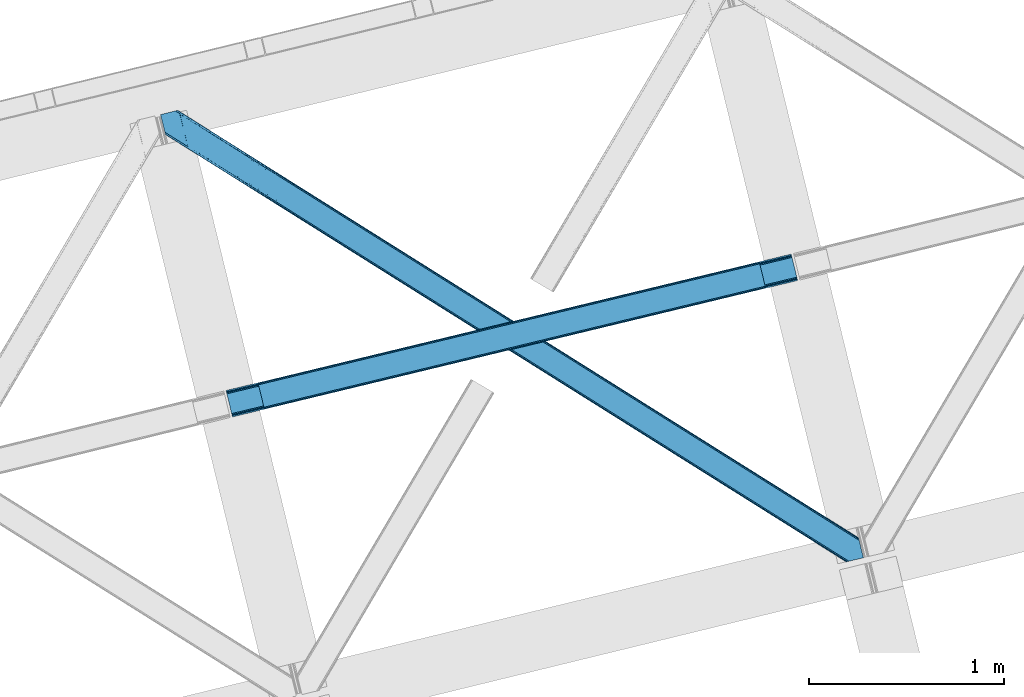
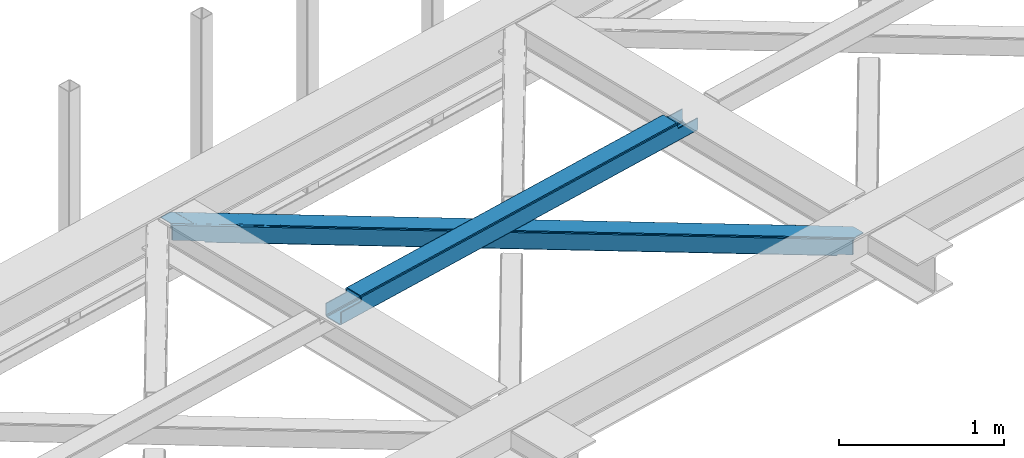
# One storey, part 20 of 67: 1 beam, 1 member.
"""IFC4 building model written with IfcOpenShell, lengths in millimetres."""

from ifc_helpers import new_model, entity, si_unit, converted_unit, derived_unit, direction, frame, origin, place, context, subcontext, project, spatial, triangles, polygons, material, type_object, element, save


model = new_model("IFC4")

# Units and contexts
model_context = context("Model", 3, precision=0.01, world=origin(), true_north=direction((6.12303176911189e-17, 1.0)))
plan_context = context("Plan", 3, precision=0.01, world=origin(), true_north=direction((6.12303176911189e-17, 1.0)))
body_context = subcontext(model_context, "Body", "Model", "MODEL_VIEW")
ifc_project = project(units=[si_unit("LENGTHUNIT", "METRE", prefix="MILLI"), si_unit("AREAUNIT", "SQUARE_METRE"), si_unit("VOLUMEUNIT", "CUBIC_METRE"), converted_unit("PLANEANGLEUNIT", "DEGREE", entity("IfcRatioMeasure", 0.0174532925199433), si_unit("PLANEANGLEUNIT", "RADIAN"), dimensions=[0, 0, 0, 0, 0, 0, 0]), si_unit("MASSUNIT", "GRAM", prefix="KILO"), derived_unit("MASSDENSITYUNIT", [(si_unit("MASSUNIT", "GRAM", prefix="KILO"), 1), (si_unit("LENGTHUNIT", "METRE"), -3)]), derived_unit("MOMENTOFINERTIAUNIT", [(si_unit("LENGTHUNIT", "METRE"), 4)]), si_unit("TIMEUNIT", "SECOND"), si_unit("FREQUENCYUNIT", "HERTZ"), si_unit("THERMODYNAMICTEMPERATUREUNIT", "DEGREE_CELSIUS"), derived_unit("THERMALTRANSMITTANCEUNIT", [(si_unit("MASSUNIT", "GRAM", prefix="KILO"), 1), (si_unit("THERMODYNAMICTEMPERATUREUNIT", "KELVIN"), -1), (si_unit("TIMEUNIT", "SECOND"), -3)]), derived_unit("VOLUMETRICFLOWRATEUNIT", [(si_unit("LENGTHUNIT", "METRE"), 3), (si_unit("TIMEUNIT", "SECOND"), -1)]), derived_unit("MASSFLOWRATEUNIT", [(si_unit("MASSUNIT", "GRAM", prefix="KILO"), 1), (si_unit("TIMEUNIT", "SECOND"), -1)]), derived_unit("ROTATIONALFREQUENCYUNIT", [(si_unit("TIMEUNIT", "SECOND"), -1)]), si_unit("ELECTRICCURRENTUNIT", "AMPERE"), si_unit("ELECTRICVOLTAGEUNIT", "VOLT"), si_unit("POWERUNIT", "WATT"), si_unit("FORCEUNIT", "NEWTON", prefix="KILO"), si_unit("ILLUMINANCEUNIT", "LUX"), si_unit("LUMINOUSFLUXUNIT", "LUMEN"), si_unit("LUMINOUSINTENSITYUNIT", "CANDELA"), derived_unit("USERDEFINED", [(si_unit("MASSUNIT", "GRAM", prefix="KILO"), -1), (si_unit("LENGTHUNIT", "METRE"), -2), (si_unit("TIMEUNIT", "SECOND"), 3), (si_unit("LUMINOUSFLUXUNIT", "LUMEN"), 1)]), derived_unit("LINEARVELOCITYUNIT", [(si_unit("LENGTHUNIT", "METRE"), 1), (si_unit("TIMEUNIT", "SECOND"), -1)]), si_unit("PRESSUREUNIT", "PASCAL"), derived_unit("USERDEFINED", [(si_unit("LENGTHUNIT", "METRE"), -2), (si_unit("MASSUNIT", "GRAM", prefix="KILO"), 1), (si_unit("TIMEUNIT", "SECOND"), -2)]), derived_unit("LINEARFORCEUNIT", [(si_unit("MASSUNIT", "GRAM", prefix="KILO"), 1), (si_unit("LENGTHUNIT", "METRE"), 1), (si_unit("TIMEUNIT", "SECOND"), -2), (si_unit("LENGTHUNIT", "METRE"), -1)]), derived_unit("PLANARFORCEUNIT", [(si_unit("MASSUNIT", "GRAM", prefix="KILO"), 1), (si_unit("LENGTHUNIT", "METRE"), 1), (si_unit("TIMEUNIT", "SECOND"), -2), (si_unit("LENGTHUNIT", "METRE"), -2)])], contexts=[model_context, plan_context])

# Site, building, storey
site_placement = place(None, origin())
site = spatial("IfcSite", under=ifc_project, at=site_placement, CompositionType="ELEMENT")
building_placement = place(site_placement, origin())
building = spatial("IfcBuilding", under=site, at=building_placement, CompositionType="ELEMENT")
storey_placement = place(building_placement, frame((0.0, 0.0, 19800.0)))
storey = spatial("IfcBuildingStorey", under=building, at=storey_placement, CompositionType="ELEMENT", Elevation=19800.0)

# Beam
ifc_material = material(Name="Metal painted (White)")
beam_type = type_object("IfcBeamType", PredefinedType="BEAM")
beam_placement = place(storey_placement, frame((-57740.4120145872, 5065.0921010713, 3967.02213739874)))
element("IfcBeam", 1, at=beam_placement, inside=storey, type_object=beam_type, material=ifc_material, ObjectType="Steel Beam", PredefinedType="BEAM", context=body_context, shape_type="Tessellation", body=[
    polygons([(195.780301044213, 46.4550586676728, 115.555285086674), (195.464822269693, 47.7492743886278, 122.252244531344), (2771.48985192152, 669.545541676776, 123.117713426555), (2771.80533069603, 668.25132595583, 116.42075398189), (194.566414729762, 51.4348889400316, 127.929650650905), (2770.59144438158, 673.231156228175, 128.795119546121), (193.221852828265, 56.9508009166206, 131.72316982947), (2769.24688248008, 678.747068204764, 132.588638724685), (191.635833926232, 63.4572627218112, 133.055273160435), (2767.66086357805, 685.253530009973, 133.920742055651), (170.084604912774, 151.868723803345, 133.055206290887), (2746.10963456458, 773.664991091508, 133.920675186102), (168.498586010742, 158.37518560857, 131.723093117664), (2744.52361566255, 780.171452896718, 132.588562012879), (167.154024109253, 163.891097585162, 127.929565595236), (2743.17905376107, 785.687364873307, 128.795034490451), (166.255616569314, 167.576712136562, 122.252153900486), (2742.28064622113, 789.372979424712, 123.117622795697), (165.940137794803, 168.870927857489, 115.55519249807), (2741.96516744662, 790.667195145647, 116.420661393281), (2740.30738059942, 797.468076767305, 101.477862601255), (2740.30738059942, 797.468076767303, 123.420656622786), (2740.62285937394, 796.173861046351, 130.117618025197), (2741.52126691387, 792.488246494948, 135.795029719952), (2742.86582881537, 786.97233451836, 139.58855724238), (2744.4518477174, 780.465872713163, 140.920670415603), (2769.31865042523, 678.452648388318, 140.920747572779), (2770.90466932728, 671.946186583087, 139.588644241809), (2772.24923122876, 666.430274606496, 135.795125063245), (2773.1476387687, 662.744660055096, 130.117718943684), (2773.46311754411, 661.450444330471, 123.420759499014), (2773.46311754321, 661.450444334177, 101.477862601255), (2771.80533069603, 668.251325955834, 101.477862601255), (2741.96516744661, 790.667195145648, 101.477862601255), (165.940137794803, 168.870927857486, 100.498086492688), (195.780301044213, 46.4550586676718, 100.498086492688), (197.438087891481, 39.6541770456987, 100.498086492688), (197.438087891403, 39.654177046016, 122.555290603803), (197.122609116892, 40.9483927669546, 129.252250048473), (196.224201576953, 44.6340073183542, 134.929656168034), (194.879639675456, 50.1499192949453, 138.723175346598), (193.293620773432, 56.6563811001544, 140.055278677564), (168.426818065593, 158.669605425, 140.055201520392), (166.840799163551, 165.17606723021, 138.723088347169), (165.496237262063, 170.6919792068, 134.929560824741), (164.597829722123, 174.377593758201, 129.252149129991), (164.282350947612, 175.671809479143, 122.555187727571), (164.282350947612, 175.671809479143, 100.498086492688), (2936.08768164363, 707.905503001759, 100.477862601264), (2936.08768164363, 707.90550300176, 25.4759431828493), (31.4979500966092, 6.80088162175, 24.5000861794941), (31.4979500966092, 6.80088162174783, 99.4980864926921), (194.80821612737, 46.2204185668087, 99.4980864926878), (1.65778684719908, 129.216750811564, 24.4999935908851), (2906.24751839422, 830.321372191575, 25.4758505942445), (2906.24751839422, 830.321372191573, 100.47786260126), (2742.93725236347, 790.901835246512, 100.47786260126), (1.65778684719908, 129.216750811561, 99.4980864926921), (2937.74546849234, 701.104621373772, 18.4759479533483), (2937.74546849731, 701.104621353716, 100.477862601264), (2774.43520246224, 661.685084426048, 100.47786260126), (33.1557369438083, 4.43975523012341e-11, 99.4980864926921), (33.1557369430373, 3.22152970966272e-09, 17.5000909499889), (2904.58973154703, 837.122253813229, 100.47786260126), (2904.58973154703, 837.122253813231, 18.4758450771161), (0.0, 136.01763243322, 17.4999880737609), (8.66293703438714e-12, 136.017632433219, 99.4980864926921), (163.310266030769, 175.437169378279, 99.4980864926878), (2772.77741561287, 668.485966056697, 100.47786260126), (2741.27946551628, 797.702716868168, 100.47786260126), (2906.56299716874, 829.027156470638, 18.7788911495745), (2907.46140470868, 825.341541919235, 13.1014850300135), (2908.80596661015, 819.825629942646, 9.30796585144909), (2910.39198551221, 813.319168137436, 7.9758625204836), (2931.94321452565, 724.907707055902, 7.97592939003242), (2933.52923342769, 718.401245250692, 9.30804256325522), (2934.87379532918, 712.885333274101, 13.1015700856834), (2935.77220286912, 709.199718722701, 18.7789817804291), (2937.4299897163, 702.398837101065, 11.7789865509282), (2936.53158217636, 706.084451652467, 6.10157485617812), (2935.18702027487, 711.600363629058, 2.30804733374998), (2933.60100137285, 718.106825434246, 0.975934160527186), (2908.73419866501, 820.120049759092, 0.975857003355134), (2907.14817976297, 826.626511564317, 2.30796033432063), (2905.80361786149, 832.142423540906, 6.10147951288502), (2904.90521032155, 835.828038092307, 11.778885632446), (196.466002974552, 39.4195369451518, 99.4980864926921), (164.968052877951, 168.636287756623, 99.4980864926921), (27.3534829786288, 23.8030856758895, 7.00007238667729), (28.9395018806531, 17.2966238706989, 8.33218555989575), (30.2840637821498, 11.7807118941088, 12.1257130823239), (31.1824713220894, 8.09509734270817, 17.8031247770739), (1.97326562170153, 127.922535090635, 17.8030341462107), (2.87167316164112, 124.236920539239, 12.125628026654), (4.21623506313788, 118.721008562646, 8.33210884808963), (5.80225396517078, 112.214546757422, 7.00000551712413), (0.315478774511121, 134.723416712281, 10.8030286290822), (1.2138863144507, 131.037802160879, 5.12562250952556), (2.55844821594746, 125.52189018429, 1.33210333096549), (4.14446711798037, 119.01542837908, 0.0), (29.0112698258193, 17.0022040542358, 7.71571720520115e-05), (30.5972887278522, 10.4957422490247, 1.33219033039485), (31.9418506293316, 4.97983027243569, 5.12571785281865), (32.8402581692712, 1.29421572103505, 10.8031295475687)], [[[1, 2, 3, 4]], [[2, 5, 6, 3]], [[5, 7, 8, 6]], [[7, 9, 10, 8]], [[11, 12, 10, 9]], [[11, 13, 14, 12]], [[13, 15, 16, 14]], [[15, 17, 18, 16]], [[17, 19, 20, 18]], [[21, 22, 23, 24, 25, 26, 27, 28, 29, 30, 31, 32, 33, 4, 3, 6, 8, 10, 12, 14, 16, 18, 20, 34]], [[35, 19, 17, 15, 13, 11, 9, 7, 5, 2, 1, 36, 37, 38, 39, 40, 41, 42, 43, 44, 45, 46, 47, 48]], [[42, 41, 28, 27]], [[41, 40, 29, 28]], [[40, 39, 30, 29]], [[39, 38, 31, 30]], [[27, 26, 43, 42]], [[47, 46, 23, 22]], [[46, 45, 24, 23]], [[45, 44, 25, 24]], [[44, 43, 26, 25]], [[33, 49, 50, 51, 52, 53, 1, 4]], [[54, 55, 56, 57, 20, 19, 35, 58]], [[59, 60, 61, 31, 38, 37, 62, 63]], [[64, 65, 66, 67, 68, 47, 22, 21]], [[61, 60, 49, 69]], [[64, 70, 57, 56]], [[65, 64, 56, 55, 71, 72, 73, 74, 75, 76, 77, 78, 50, 49, 60, 59, 79, 80, 81, 82, 83, 84, 85, 86]], [[87, 53, 52, 62]], [[67, 58, 88, 68]], [[89, 90, 76, 75]], [[90, 91, 77, 76]], [[91, 92, 78, 77]], [[92, 51, 50, 78]], [[54, 93, 71, 55]], [[93, 94, 72, 71]], [[94, 95, 73, 72]], [[95, 96, 74, 73]], [[89, 75, 74, 96]], [[66, 97, 98, 99, 100, 101, 102, 103, 104, 63, 62, 52, 51, 92, 91, 90, 89, 96, 95, 94, 93, 54, 58, 67]], [[63, 104, 79, 59]], [[104, 103, 80, 79]], [[103, 102, 81, 80]], [[102, 101, 82, 81]], [[100, 99, 84, 83]], [[99, 98, 85, 84]], [[98, 97, 86, 85]], [[97, 66, 65, 86]], [[83, 82, 101, 100]]], closed=False),
])

# Member
member_type = type_object("IfcMemberType", PredefinedType="BRACE")
member_placement = place(storey_placement, frame((-58076.8457519531, 4319.81946258545, 3823.99987792968)))
element("IfcMember", 2, at=member_placement, inside=storey, type_object=member_type, ObjectType="Steel Horizontal Brace", PredefinedType="BRACE", context=body_context, shape_type="Tessellation", body=[
    triangles([(207.717553710943, 2101.81647491455, 0.0), (172.040661621097, 2248.17905273437, 0.0), (3404.48986816406, 219.293300628662, 0.0), (3440.17141113282, 72.9304321289064, 0.0), (202.587634277348, 2097.1307144165, 1.33247680664135), (208.508203125006, 2098.57481231689, 0.155804443358647), (3442.44569091797, 63.5952461242678, 1.33247680664135), (3445.6640991211, 50.3934356689451, 10.8039916992202), (3446.115234375, 48.5365722656252, 17.5012573242202), (187.951318359381, 2093.56290893555, 17.5012573242202), (189.755859375, 2094.00299835205, 10.8039916992202), (3444.37580566407, 55.6814849853517, 5.12526855468968), (194.895080566406, 2095.25582885742, 5.12526855468968), (3405.08983154297, 238.005821228027, 10.8039916992202), (3400.22036132813, 236.818393707275, 5.32758178711083), (167.83626708985, 2265.42799987793, 5.12526855468968), (166.547973632813, 2270.71604919434, 10.8039916992202), (3400.29942626954, 236.497483062744, 5.1694519042976), (3402.21558837891, 228.628195953369, 1.33247680664135), (169.766381835943, 2257.51394805908, 1.33247680664135), (3406.8943725586, 238.445619964599, 17.5012573242202), (166.096838378908, 2272.57291259766, 17.5012573242202), (3401.19239501953, 237.055007171631, 18.5197998046897), (3406.8943725586, 238.445619964599, 18.5197998046897), (3400.50406494141, 236.887575531006, 18.2267944335945), (3400.82032470703, 236.96460571289, 18.4453857421868), (3400.29477539063, 236.836415863037, 17.9035583496116), (3400.22036132813, 236.818393707275, 17.5198608398459), (3402.04350585938, 231.951539611817, 18.4453857421868), (3401.8388671875, 231.936424255371, 18.1454040527351), (3401.62027587891, 231.920436859131, 17.8198425292976), (3401.6109741211, 231.919564819336, 17.8058898925774), (3401.41563720704, 231.905321502685, 17.5198608398459), (3402.49929199219, 231.698357391358, 18.5197998046897), (3586.9019897461, 125.462400054932, 18.5197998046897), (3589.63670654297, 114.236631774902, 18.5197998046897), (204.378222656254, 2097.56789703369, 12.1248413085959), (208.508203125006, 2098.57481231689, 9.69243164062573), (199.652929687501, 2096.4150604248, 17.9802978515618), (198.425097656254, 2096.11566009521, 19.5011352539077), (187.951318359381, 2093.56290893555, 19.5011352539077), (25.3100830078183, 2195.64679412842, 19.5011352539077), (22.6823364257871, 2206.42171783447, 19.5011352539077), (3437.79016113281, 82.6879760742186, 6.99957275390625), (3404.59683837891, 218.870942687989, 8.3320495605476), (3402.66672363281, 226.784703826905, 12.1248413085959), (3406.87111816407, 209.53575668335, 6.99957275390625), (3443.24564208985, 60.3184112548824, 17.5198608398459), (3441.99455566407, 65.4390289306639, 12.1248413085959), (3446.115234375, 48.5365722656252, 17.5198608398459), (3440.06444091797, 73.3527900695799, 8.3320495605476), (1232.85963134766, 1574.07833862305, 6.99957275390625), (640.584155273442, 1945.82774047852, 6.99957275390625), (602.800415039063, 1862.1026184082, 6.99957275390625), (1195.07589111329, 1490.35496063232, 6.99957275390625), (1825.13510742188, 1202.32951812744, 6.99957275390625), (1787.3467163086, 1118.60788421631, 6.99957275390625), (205.340954589847, 2111.57401885986, 6.99957275390625), (174.421911621095, 2238.42150878906, 6.99957275390625), (2971.89301757813, 375.112859344483, 6.99957275390625), (3009.69071044922, 458.831295776367, 6.99957275390625), (2379.62219238281, 746.86022644043, 6.99957275390625), (2417.415234375, 830.580697631836, 6.99957275390625), (168.836206054693, 2261.33697052002, 18.501196289064), (166.096838378908, 2272.57291259766, 18.501196289064), (168.971081542972, 2260.78584136963, 17.8803039550803), (170.217517089848, 2255.67045593262, 12.1248413085959), (172.142980957033, 2247.75640411377, 8.3320495605476), (207.559423828126, 2102.47631835938, 8.8831787109375), (3444.59439697266, 58.9995964050295, 18.5197998046897), (3447.32911376953, 47.7738281250004, 18.5197998046897), (3447.04541015625, 47.9543403625485, 18.2849304199226), (3444.26883544922, 59.3176002502441, 18.2802795410171), (3446.72449951172, 48.1552001953123, 18.0198303222678), (3443.92001953125, 59.6591491699219, 18.0198303222678), (3446.40358886719, 48.356350708008, 17.757055664064), (3443.62701416016, 59.9422714233397, 17.8058898925774), (3443.57120361328, 60.0006980895996, 17.7617065429695), (3534.35635986328, 2.65972137451172, 18.5197998046897), (3523.44539794922, 0.0, 18.5197998046897), (2962.59125976563, 360.290798950195, 24.5008300781265), (2963.29819335938, 361.419218444824, 17.8035644531265), (3532.92854003907, 2.31206817626935, 24.5008300781265), (2965.31667480469, 364.632103729248, 12.1248413085959), (596.224072265628, 1851.62186279297, 12.1248413085959), (599.242492675781, 1856.43029022217, 8.3320495605476), (594.205590820318, 1848.40868682861, 17.8035644531265), (593.498657226563, 1847.28026733398, 24.5008300781265), (22.9288330078125, 2205.40433807373, 24.5008300781265), (2968.33509521485, 369.440821838379, 8.3320495605476), (2370.32043457031, 732.038456726074, 24.5008300781265), (2371.02736816407, 733.16629486084, 17.8035644531265), (1778.75189208984, 1104.91395263672, 17.8035644531265), (1778.0449584961, 1103.78553314209, 24.5008300781265), (1186.48106689454, 1476.66102905273, 17.8035644531265), (1185.77413330079, 1475.53319091797, 24.5008300781265), (2373.04119873047, 736.379470825195, 12.1248413085959), (1780.77037353516, 1108.12712860107, 12.1248413085959), (1188.49489746094, 1479.87420501709, 12.1248413085959), (2376.05961914063, 741.188479614258, 8.3320495605476), (1783.78879394531, 1112.93555603027, 8.3320495605476), (1191.5133178711, 1484.68263244629, 8.3320495605476), (2965.14924316407, 350.421343231201, 122.499499511719), (2371.32037353516, 723.143650817871, 122.499499511719), (3523.44539794922, 0.0, 122.499499511719), (1777.49615478516, 1095.86624908447, 122.499499511719), (1183.66728515625, 1468.58884735107, 122.499499511719), (589.843066406254, 1841.31144561768, 122.499499511719), (25.3100830078183, 2195.64679412842, 122.499499511719), (3532.92854003907, 2.31206817626935, 115.499926757813), (22.9288330078125, 2205.40433807373, 115.499926757813), (3534.73308105469, 2.75186691284216, 122.197192382813), (22.4776977539077, 2207.26120147705, 122.197192382813), (3539.8723022461, 4.00469741821325, 127.873590087893), (21.1894042968779, 2212.54925079346, 127.873590087893), (3547.56485595703, 5.87958297729529, 131.668707275392), (19.2592895507842, 2220.4633026123, 131.668707275392), (3556.63872070313, 8.09165725708044, 133.001184082033), (16.9850097656308, 2229.79819793701, 133.001184082033), (3525.24993896484, 0.440089416503724, 129.196765136719), (3530.38916015625, 1.69291992187482, 134.87548828125), (3547.15557861328, 5.77958908081018, 140.00075683594), (3612.21207275391, 21.6376327514645, 140.00075683594), (3612.21207275391, 21.6376327514645, 133.001184082033), (3538.08171386719, 3.56780548095685, 138.668280029298), (168.515295410158, 2261.63113861084, 18.7407165527366), (165.808483886722, 2272.75313415527, 18.7360656738274), (168.171130371098, 2261.94914245605, 19.0011657714858), (165.487573242193, 2272.95428466797, 19.0011657714858), (167.826965332031, 2262.26714630127, 19.2592895507805), (165.166662597658, 2273.1548538208, 19.2639404296897), (167.506054687503, 2262.56131439209, 19.5011352539077), (164.878308105472, 2273.33565673828, 19.5011352539077), (78.2928955078169, 2318.55673370361, 19.5011352539077), (88.7666748046904, 2321.10948486328, 19.5011352539077), (649.178979492193, 1959.52167205811, 17.8035644531265), (3018.28553466797, 472.525227355957, 17.8035644531265), (3016.26705322266, 469.312342071533, 12.1248413085959), (3018.99246826172, 473.653646850586, 24.5008300781265), (3589.2832397461, 115.704856109619, 24.5008300781265), (649.890563964844, 1960.65009155273, 24.5008300781265), (79.2835327148496, 2318.79799804688, 24.5008300781265), (3013.2486328125, 464.503623962402, 8.3320495605476), (644.146728515625, 1951.49948730469, 8.3320495605476), (647.165148925786, 1956.30849609375, 12.1248413085959), (2420.97315673828, 836.252444458008, 8.3320495605476), (1828.69768066407, 1208.00184631348, 8.3320495605476), (1236.42220458985, 1579.75066680908, 8.3320495605476), (2423.99157714844, 841.06145324707, 12.1248413085959), (1831.71610107422, 1212.81027374268, 12.1248413085959), (1239.440625, 1584.55967559814, 12.1248413085959), (2426.01005859375, 844.274629211426, 17.8035644531265), (1833.73458251954, 1216.02344970703, 17.8035644531265), (1241.45445556641, 1587.77227020264, 17.8035644531265), (2426.7169921875, 845.402467346192, 24.5008300781265), (1834.44151611329, 1217.15186920166, 24.5008300781265), (1242.16604003907, 1588.90068969727, 24.5008300781265), (1247.70523681641, 1593.6864440918, 122.499499511719), (653.815905761723, 1966.45090026855, 122.499499511719), (1841.59921875, 1220.9225692749, 122.499499511719), (3586.9019897461, 125.462400054932, 122.499499511719), (2435.4932006836, 848.158694458008, 122.499499511719), (3029.38718261719, 475.394528961182, 122.499499511719), (88.7666748046904, 2321.10948486328, 122.499499511719), (3591.02266845704, 108.560234069824, 127.873590087893), (3588.64606933594, 118.317487335205, 134.87548828125), (3590.57153320313, 110.403726196289, 138.668280029298), (3592.95278320313, 100.646182250976, 131.668707275392), (3595.22706298828, 91.3109962463377, 133.001184082033), (3592.85046386719, 101.068540191651, 140.00075683594), (3589.734375, 113.847992706299, 122.197192382813), (3587.353125, 123.605536651611, 129.196765136719), (3589.2832397461, 115.704856109619, 115.499926757813), (55.5733520507856, 2313.01811828613, 133.001184082033), (0.0, 2299.47185211182, 133.001184082033), (79.2835327148496, 2318.79799804688, 115.499926757813), (64.647216796875, 2315.23019256592, 131.668707275392), (72.3397705078169, 2317.105078125, 127.873590087893), (77.4789916992231, 2318.35790863037, 122.197192382813), (76.0651245117188, 2318.01316223145, 138.000878906252), (81.8229125976577, 2319.41656494141, 134.87548828125), (86.962133789064, 2320.66939544678, 129.196765136719), (0.0, 2299.47185211182, 138.000878906252), (24.8542968750044, 2197.50365753174, 129.196765136719), (23.5660034179746, 2202.79170684814, 134.87548828125), (22.1242309570371, 2208.71692657471, 138.000878906252), (98.1940063476577, 2304.12389373779, 138.000878906252), (139.391491699222, 2135.11211700439, 138.000878906252), (599.144824218754, 1856.13379669189, 140.00075683594), (139.828674316406, 2137.54568939209, 139.000817871096), (140.051916503908, 2136.3818069458, 138.668280029298), (137.847399902348, 2145.67368164062, 140.00075683594), (592.563830566411, 1845.65304107666, 134.87548828125), (139.805419921875, 2135.0249130249, 138.075292968751), (595.582250976564, 1850.46146850586, 138.668280029298), (139.921691894531, 2135.65917663574, 138.352020263672), (140.037963867188, 2136.29576568604, 138.631072998047), (2974.45100097657, 365.243403625488, 140.00075683594), (2970.89307861328, 359.571075439453, 138.668280029298), (2967.87465820313, 354.762357330323, 134.87548828125), (2965.85617675781, 351.549472045898, 129.196765136719), (590.550000000003, 1842.4398651123, 129.196765136719), (2372.03195800781, 724.2720703125, 129.196765136719), (1778.20308837891, 1096.9946685791, 129.196765136719), (1184.37421875, 1469.7172668457, 129.196765136719), (2374.04578857422, 727.485246276856, 134.87548828125), (1780.22156982422, 1100.20784454346, 134.87548828125), (1186.39270019531, 1472.93044281006, 134.87548828125), (2377.06420898438, 732.293673706055, 138.668280029298), (1783.23999023438, 1105.01627197266, 138.668280029298), (1189.41112060547, 1477.73887023926, 138.668280029298), (2380.62678222657, 737.966001892089, 140.00075683594), (1786.79791259766, 1110.68860015869, 140.00075683594), (1192.97369384766, 1483.41119842529, 140.00075683594), (651.090490722658, 1962.10930480957, 134.87548828125), (98.7056030273452, 2303.62683105469, 138.075292968751), (99.1985961914106, 2302.47515716553, 138.384576416018), (648.072070312504, 1957.30087738037, 138.668280029298), (99.5985717773438, 2301.53800506592, 138.633398437501), (644.509497070314, 1951.62854919434, 140.00075683594), (100.184582519534, 2300.16425170898, 139.000817871096), (102.1658569336, 2292.03684082031, 140.00075683594), (3028.68024902344, 474.266400146485, 129.196765136719), (3026.66176757813, 471.053224182129, 134.87548828125), (3023.64334716797, 466.244506072998, 138.668280029298), (3020.08077392579, 460.572177886963, 140.00075683594), (653.104321289065, 1965.32248077393, 129.196765136719), (2429.74936523438, 839.008671569824, 138.668280029298), (2426.1914428711, 833.336343383789, 140.00075683594), (1835.85538330078, 1211.77254638672, 138.668280029298), (1832.2974609375, 1206.10021820068, 140.00075683594), (1241.9660522461, 1584.53642120361, 138.668280029298), (1238.40347900391, 1578.86409301758, 140.00075683594), (2432.76778564454, 843.817098999023, 134.87548828125), (1838.87380371094, 1216.58155517578, 134.87548828125), (1244.98447265625, 1589.34542999268, 134.87548828125), (2434.78626708985, 847.030274963379, 129.196765136719), (1840.89228515625, 1219.79414978027, 129.196765136719), (1246.99830322266, 1592.55802459717, 129.196765136719)], [[1, 2, 3], [3, 4, 1], [5, 6, 4], [4, 7, 5], [8, 9, 10], [10, 11, 8], [12, 8, 11], [11, 13, 12], [7, 12, 13], [13, 5, 7], [6, 1, 4], [14, 15, 16], [16, 17, 14], [18, 19, 20], [19, 3, 2], [2, 20, 19], [20, 16, 18], [15, 18, 16], [21, 14, 17], [17, 22, 21], [23, 21, 24], [25, 23, 26], [23, 25, 27], [23, 27, 28], [21, 23, 28], [28, 15, 14], [14, 21, 28], [26, 29, 30], [25, 30, 31], [27, 32, 33], [27, 31, 32], [33, 28, 27], [31, 27, 25], [30, 25, 26], [23, 34, 29], [29, 26, 23], [34, 24, 35], [24, 34, 23], [35, 36, 34], [37, 38, 5], [37, 5, 13], [13, 11, 39], [38, 6, 5], [39, 37, 13], [11, 10, 40], [41, 40, 10], [11, 40, 39], [42, 43, 40], [40, 41, 42], [3, 44, 4], [45, 19, 46], [33, 15, 28], [18, 33, 46], [33, 18, 15], [3, 19, 45], [46, 19, 18], [3, 47, 44], [45, 47, 3], [8, 48, 9], [48, 12, 49], [12, 48, 8], [50, 9, 48], [49, 7, 51], [51, 4, 44], [4, 51, 7], [49, 12, 7], [52, 53, 54], [54, 55, 52], [55, 56, 52], [56, 55, 57], [53, 58, 54], [53, 59, 58], [60, 61, 62], [61, 60, 47], [44, 47, 60], [63, 62, 61], [57, 63, 56], [62, 63, 57], [17, 22, 64], [22, 65, 64], [66, 17, 64], [66, 16, 17], [67, 16, 66], [20, 67, 68], [67, 20, 16], [2, 20, 68], [68, 59, 2], [69, 38, 6], [69, 1, 58], [1, 59, 58], [59, 1, 2], [69, 6, 1], [70, 71, 72], [72, 73, 70], [73, 72, 74], [74, 75, 73], [75, 76, 77], [75, 74, 76], [76, 78, 77], [78, 76, 50], [50, 48, 78], [71, 70, 79], [79, 80, 71], [81, 70, 73], [73, 82, 81], [73, 75, 82], [75, 77, 82], [83, 79, 70], [70, 81, 83], [82, 77, 78], [78, 84, 82], [78, 48, 84], [48, 49, 84], [54, 58, 69], [85, 86, 38], [86, 69, 38], [87, 85, 37], [88, 87, 39], [39, 40, 88], [88, 40, 89], [43, 89, 40], [37, 39, 87], [38, 37, 85], [69, 86, 54], [51, 44, 90], [60, 90, 44], [49, 51, 84], [90, 84, 51], [81, 82, 91], [92, 91, 82], [91, 92, 93], [93, 94, 91], [94, 93, 95], [95, 96, 94], [96, 95, 87], [87, 88, 96], [82, 84, 97], [97, 92, 82], [92, 97, 98], [98, 93, 92], [93, 98, 99], [99, 95, 93], [95, 99, 85], [85, 87, 95], [84, 90, 100], [100, 97, 84], [97, 100, 101], [101, 98, 97], [98, 101, 102], [102, 99, 98], [99, 102, 86], [86, 85, 99], [90, 60, 100], [62, 100, 60], [100, 62, 101], [57, 101, 62], [101, 57, 55], [55, 102, 101], [102, 55, 54], [54, 86, 102], [9, 103, 104], [71, 105, 72], [71, 80, 105], [105, 74, 72], [50, 105, 103], [50, 76, 105], [76, 74, 105], [9, 50, 103], [106, 10, 9], [10, 107, 108], [109, 41, 108], [106, 107, 10], [106, 9, 104], [10, 108, 41], [42, 41, 109], [81, 110, 83], [110, 81, 91], [110, 94, 111], [94, 110, 91], [88, 89, 111], [96, 111, 94], [111, 96, 88], [112, 110, 111], [111, 113, 112], [114, 112, 113], [113, 115, 114], [116, 114, 115], [115, 117, 116], [118, 116, 117], [117, 119, 118], [112, 120, 121], [118, 122, 123], [123, 124, 118], [118, 116, 122], [116, 125, 122], [114, 125, 116], [121, 125, 114], [112, 105, 120], [110, 105, 112], [121, 114, 112], [80, 83, 79], [110, 80, 105], [83, 80, 110], [65, 64, 126], [126, 127, 65], [127, 126, 128], [128, 129, 127], [129, 128, 130], [130, 131, 129], [131, 130, 132], [132, 133, 131], [134, 135, 133], [133, 132, 134], [136, 66, 67], [137, 138, 33], [138, 46, 33], [139, 29, 34], [34, 140, 139], [34, 36, 140], [139, 137, 32], [32, 31, 139], [30, 29, 139], [139, 31, 30], [141, 130, 128], [141, 132, 130], [128, 136, 141], [64, 136, 126], [128, 126, 136], [64, 66, 136], [132, 141, 142], [142, 134, 132], [33, 32, 137], [45, 46, 143], [138, 143, 46], [47, 45, 61], [143, 61, 45], [53, 144, 59], [68, 59, 144], [144, 145, 68], [67, 68, 145], [67, 145, 136], [61, 143, 146], [146, 63, 61], [63, 146, 147], [147, 56, 63], [56, 147, 148], [148, 52, 56], [52, 148, 144], [144, 53, 52], [143, 138, 146], [149, 146, 138], [146, 149, 147], [150, 147, 149], [147, 150, 148], [151, 148, 150], [148, 151, 144], [145, 144, 151], [138, 137, 152], [152, 149, 138], [149, 152, 153], [153, 150, 149], [150, 153, 154], [154, 151, 150], [151, 154, 136], [136, 145, 151], [137, 139, 152], [155, 152, 139], [152, 155, 153], [156, 153, 155], [153, 156, 154], [157, 154, 156], [154, 157, 136], [141, 136, 157], [158, 22, 159], [22, 158, 160], [161, 35, 24], [21, 160, 162], [21, 163, 24], [160, 21, 22], [24, 163, 161], [162, 163, 21], [164, 159, 65], [164, 65, 127], [22, 65, 159], [129, 164, 127], [164, 129, 131], [131, 133, 164], [135, 164, 133], [165, 166, 167], [165, 167, 168], [169, 168, 170], [171, 166, 165], [124, 169, 123], [170, 123, 169], [168, 167, 170], [172, 166, 171], [35, 161, 173], [140, 35, 173], [35, 140, 36], [172, 171, 161], [171, 173, 161], [119, 174, 169], [174, 119, 175], [169, 118, 119], [124, 118, 169], [156, 173, 176], [173, 155, 139], [156, 155, 173], [139, 140, 173], [157, 176, 141], [176, 157, 156], [142, 141, 176], [168, 169, 174], [174, 177, 168], [165, 168, 177], [177, 178, 165], [171, 165, 178], [178, 179, 171], [173, 171, 179], [179, 176, 173], [177, 174, 180], [181, 178, 180], [177, 180, 178], [179, 181, 182], [174, 183, 180], [174, 175, 183], [179, 178, 181], [164, 176, 179], [176, 164, 135], [142, 135, 134], [135, 142, 176], [164, 179, 182], [111, 42, 109], [184, 113, 109], [113, 184, 185], [113, 111, 109], [89, 42, 111], [43, 42, 89], [115, 113, 185], [186, 119, 117], [119, 186, 183], [183, 175, 119], [117, 115, 186], [186, 115, 185], [180, 186, 187], [180, 183, 186], [188, 187, 186], [189, 190, 191], [189, 192, 190], [193, 194, 188], [188, 185, 193], [188, 186, 185], [195, 196, 194], [195, 191, 196], [194, 193, 195], [197, 195, 189], [125, 122, 198], [198, 199, 125], [121, 125, 199], [199, 200, 121], [120, 121, 200], [200, 201, 120], [105, 120, 201], [201, 103, 105], [108, 202, 109], [184, 109, 202], [202, 193, 184], [185, 184, 193], [103, 201, 104], [203, 104, 201], [104, 203, 204], [204, 106, 104], [106, 204, 205], [205, 107, 106], [107, 205, 108], [202, 108, 205], [201, 200, 203], [206, 203, 200], [203, 206, 204], [207, 204, 206], [204, 207, 208], [208, 205, 204], [205, 208, 193], [193, 202, 205], [200, 199, 209], [209, 206, 200], [206, 209, 210], [210, 207, 206], [207, 210, 208], [211, 208, 210], [208, 211, 193], [195, 193, 211], [199, 198, 209], [212, 209, 198], [209, 212, 213], [213, 210, 209], [210, 213, 214], [214, 211, 210], [211, 214, 189], [189, 195, 211], [215, 216, 217], [217, 218, 215], [217, 219, 218], [187, 215, 181], [181, 180, 187], [219, 220, 218], [219, 221, 220], [221, 222, 220], [172, 161, 223], [163, 223, 161], [166, 172, 224], [223, 224, 172], [167, 166, 225], [224, 225, 166], [170, 167, 226], [225, 226, 167], [215, 227, 182], [182, 181, 215], [227, 159, 164], [164, 182, 227], [226, 225, 228], [228, 229, 226], [229, 228, 230], [230, 231, 229], [231, 230, 232], [232, 233, 231], [233, 232, 218], [218, 220, 233], [225, 224, 234], [234, 228, 225], [228, 234, 235], [235, 230, 228], [230, 235, 236], [236, 232, 230], [232, 236, 215], [215, 218, 232], [224, 223, 234], [237, 234, 223], [234, 237, 235], [238, 235, 237], [235, 238, 236], [239, 236, 238], [236, 239, 215], [227, 215, 239], [223, 163, 162], [162, 237, 223], [237, 162, 160], [160, 238, 237], [238, 160, 158], [158, 239, 238], [239, 158, 159], [159, 227, 239], [214, 233, 189], [233, 214, 231], [213, 231, 214], [231, 213, 229], [222, 192, 220], [189, 220, 192], [220, 189, 233], [170, 226, 198], [198, 122, 170], [123, 170, 122], [226, 212, 198], [212, 229, 213], [226, 229, 212], [197, 190, 221], [221, 219, 197], [219, 217, 194], [217, 216, 194], [222, 221, 192], [190, 192, 221]]),
])

save(model, "model.ifc")
